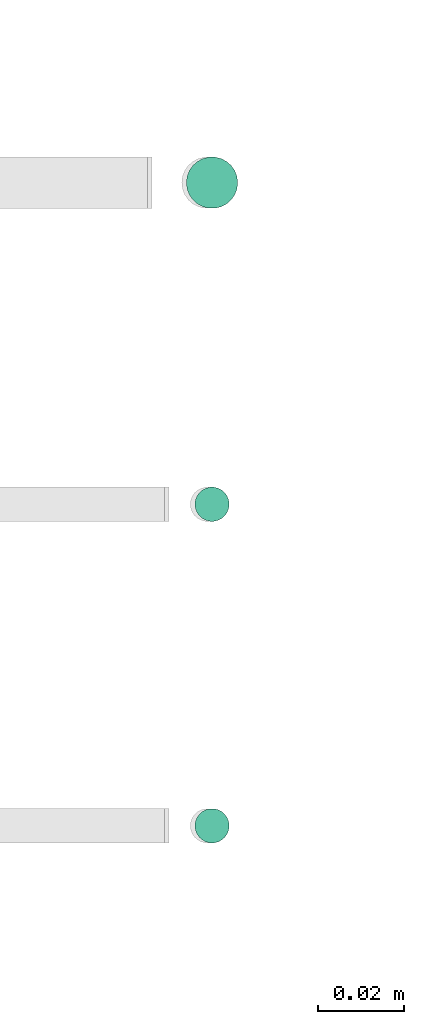
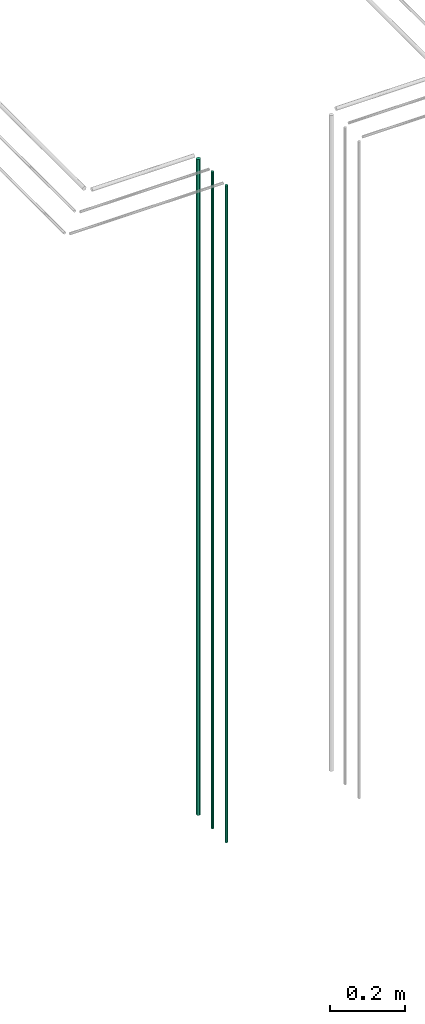
# One storey, part 43 of 331: 3 flow segments.
"""IFC2X3 building model written with IfcOpenShell, lengths in millimetres."""

from ifc_helpers import new_model, entity, si_unit, converted_unit, derived_unit, direction, frame, frame_2d, origin, origin_2d_with_axis, place, context, subcontext, project, spatial, circle, extrude, type_object, element, save


model = new_model("IFC2X3")

# Units and contexts
model_context = context("Model", 3, precision=0.01, world=origin(), true_north=direction((6.12303176911189e-17, 1.0)))
body_context = subcontext(model_context, "Body", "Model", "MODEL_VIEW")
ifc_project = project(units=[si_unit("LENGTHUNIT", "METRE", prefix="MILLI"), si_unit("AREAUNIT", "SQUARE_METRE"), si_unit("VOLUMEUNIT", "CUBIC_METRE"), converted_unit("PLANEANGLEUNIT", "DEGREE", entity("IfcRatioMeasure", 0.0174532925199433), si_unit("PLANEANGLEUNIT", "RADIAN"), dimensions=[0, 0, 0, 0, 0, 0, 0]), si_unit("MASSUNIT", "GRAM", prefix="KILO"), derived_unit("MASSDENSITYUNIT", [(si_unit("MASSUNIT", "GRAM", prefix="KILO"), 1), (si_unit("LENGTHUNIT", "METRE"), -3)]), derived_unit("MOMENTOFINERTIAUNIT", [(si_unit("LENGTHUNIT", "METRE"), 4)]), si_unit("TIMEUNIT", "SECOND"), si_unit("FREQUENCYUNIT", "HERTZ"), si_unit("THERMODYNAMICTEMPERATUREUNIT", "DEGREE_CELSIUS"), derived_unit("THERMALTRANSMITTANCEUNIT", [(si_unit("MASSUNIT", "GRAM", prefix="KILO"), 1), (si_unit("THERMODYNAMICTEMPERATUREUNIT", "KELVIN"), -1), (si_unit("TIMEUNIT", "SECOND"), -3)]), derived_unit("VOLUMETRICFLOWRATEUNIT", [(si_unit("LENGTHUNIT", "METRE"), 3), (si_unit("TIMEUNIT", "SECOND"), -1)]), derived_unit("MASSFLOWRATEUNIT", [(si_unit("MASSUNIT", "GRAM", prefix="KILO"), 1), (si_unit("TIMEUNIT", "SECOND"), -1)]), derived_unit("ROTATIONALFREQUENCYUNIT", [(si_unit("TIMEUNIT", "SECOND"), -1)]), si_unit("ELECTRICCURRENTUNIT", "AMPERE"), si_unit("ELECTRICVOLTAGEUNIT", "VOLT"), si_unit("POWERUNIT", "WATT"), si_unit("FORCEUNIT", "NEWTON", prefix="KILO"), si_unit("ILLUMINANCEUNIT", "LUX"), si_unit("LUMINOUSFLUXUNIT", "LUMEN"), si_unit("LUMINOUSINTENSITYUNIT", "CANDELA"), derived_unit("USERDEFINED", [(si_unit("MASSUNIT", "GRAM", prefix="KILO"), -1), (si_unit("LENGTHUNIT", "METRE"), -2), (si_unit("TIMEUNIT", "SECOND"), 3), (si_unit("LUMINOUSFLUXUNIT", "LUMEN"), 1)]), derived_unit("LINEARVELOCITYUNIT", [(si_unit("LENGTHUNIT", "METRE"), 1), (si_unit("TIMEUNIT", "SECOND"), -1)]), si_unit("PRESSUREUNIT", "PASCAL"), derived_unit("USERDEFINED", [(si_unit("LENGTHUNIT", "METRE"), -2), (si_unit("MASSUNIT", "GRAM", prefix="KILO"), 1), (si_unit("TIMEUNIT", "SECOND"), -2)]), derived_unit("LINEARFORCEUNIT", [(si_unit("MASSUNIT", "GRAM", prefix="KILO"), 1), (si_unit("LENGTHUNIT", "METRE"), 1), (si_unit("TIMEUNIT", "SECOND"), -2), (si_unit("LENGTHUNIT", "METRE"), -1)]), derived_unit("PLANARFORCEUNIT", [(si_unit("MASSUNIT", "GRAM", prefix="KILO"), 1), (si_unit("LENGTHUNIT", "METRE"), 1), (si_unit("TIMEUNIT", "SECOND"), -2), (si_unit("LENGTHUNIT", "METRE"), -2)])], contexts=[model_context])

# Site, building, storey
site_placement = place(None, frame((0.0, -0.00077364408347762, 0.0)))
site = spatial("IfcSite", under=ifc_project, at=site_placement, CompositionType="ELEMENT")
building_placement = place(site_placement, origin())
building = spatial("IfcBuilding", under=site, at=building_placement, CompositionType="ELEMENT")
storey_placement = place(building_placement, origin())
storey = spatial("IfcBuildingStorey", under=building, at=storey_placement, CompositionType="ELEMENT", Elevation=0.0)

# Flow segments
pipe_segment_type = type_object("IfcPipeSegmentType", PredefinedType="NOTDEFINED")
flow_segment_1_placement = place(storey_placement, frame((53157.8976593377, 1343.89349484363, 12990.0)))
element("IfcFlowSegment", 1, at=flow_segment_1_placement, inside=storey, type_object=pipe_segment_type, context=body_context, shape_type="SweptSolid", body=[
    extrude(circle(Radius=6.0, at=origin_2d_with_axis()), frame((7.59527223591454, 7.59527223591589, 0.0)), (0.0, 0.0, 1.0), 2146.0),
])
flow_segment_2_placement = place(storey_placement, frame((53159.8976593377, 1270.89349484379, 12990.0)))
element("IfcFlowSegment", 2, at=flow_segment_2_placement, inside=storey, type_object=pipe_segment_type, context=body_context, shape_type="SweptSolid", body=[
    extrude(circle(Radius=4.0, at=origin_2d_with_axis()), frame((5.59527223591499, 5.5952722359158, 0.0)), (0.0, 0.0, 1.0), 2150.00000000001),
])
flow_segment_3_placement = place(storey_placement, frame((53159.8976593377, 1195.89349484369, 12990.0)))
element("IfcFlowSegment", 3, at=flow_segment_3_placement, inside=storey, type_object=pipe_segment_type, context=body_context, shape_type="SweptSolid", body=[
    extrude(circle(Radius=4.0, at=frame_2d((0.0, 1.35358391162299e-13), x_axis=(1.0, 0.0))), frame((5.59527223591499, 5.59527223591594, 0.0)), (0.0, 0.0, 1.0), 2150.00000000001),
])

save(model, "model.ifc")
